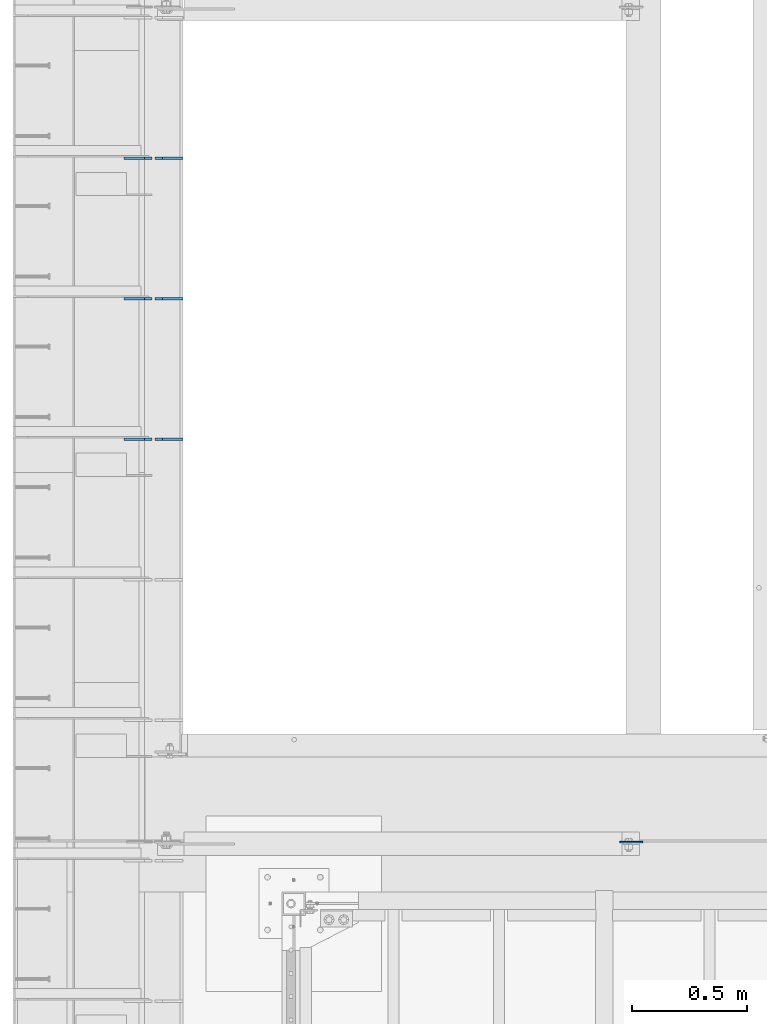
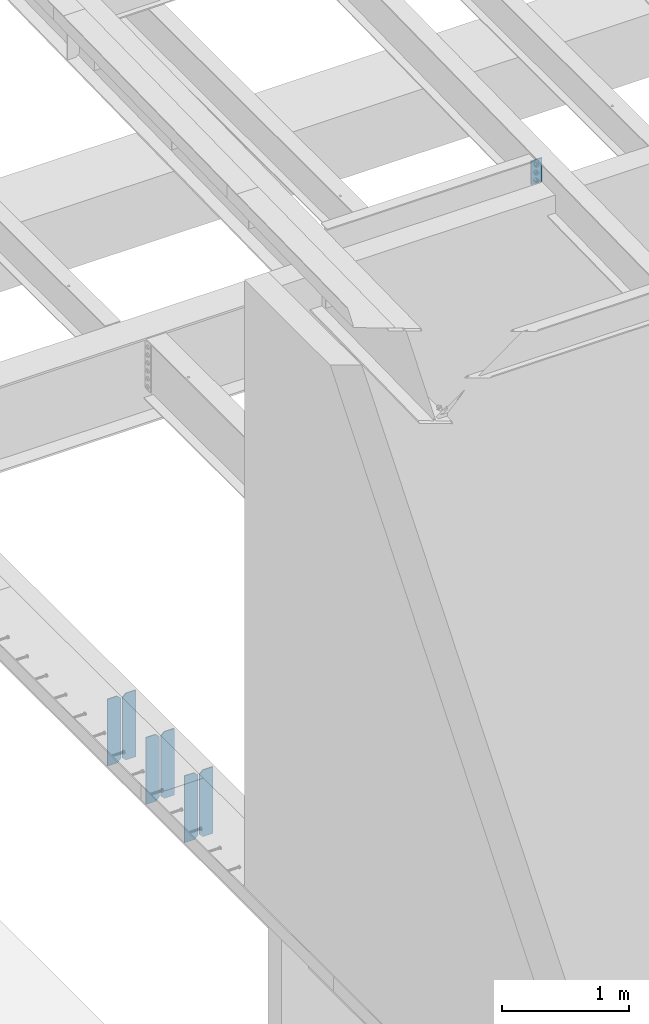
# One storey, part 1516 of 1763: 7 plates, 2 elements without a shape of their own.
"""IFC2X3 building model written with IfcOpenShell, lengths in millimetres."""

from ifc_helpers import new_model, si_unit, frame, origin_with_axes, place, context, subcontext, project, spatial, faceted_brep, material, type_object, element, aggregate, save


model = new_model("IFC2X3")

# Units and contexts
model_context = context("Model", 3, precision=1e-05, world=origin_with_axes())
body_context = subcontext(model_context, "Body", "Model", "MODEL_VIEW")
ifc_project = project(units=[si_unit("LENGTHUNIT", "METRE", prefix="MILLI"), si_unit("AREAUNIT", "SQUARE_METRE"), si_unit("VOLUMEUNIT", "CUBIC_METRE"), si_unit("MASSUNIT", "GRAM", prefix="KILO"), si_unit("TIMEUNIT", "SECOND"), si_unit("PLANEANGLEUNIT", "RADIAN"), si_unit("SOLIDANGLEUNIT", "STERADIAN"), si_unit("THERMODYNAMICTEMPERATUREUNIT", "DEGREE_CELSIUS"), si_unit("LUMINOUSINTENSITYUNIT", "LUMEN")], contexts=[model_context])

# Site, building, storey
site_placement = place(None, origin_with_axes())
site = spatial("IfcSite", under=ifc_project, at=site_placement, CompositionType="ELEMENT")
building_placement = place(site_placement, origin_with_axes())
building = spatial("IfcBuilding", under=site, at=building_placement, Name="Undefined", CompositionType="ELEMENT")
storey_placement = place(building_placement, origin_with_axes())
storey = spatial("IfcBuildingStorey", under=building, at=storey_placement, Name="Undefined", CompositionType="ELEMENT", Elevation=0.0)

# Assembly, plates
assembly_1_placement = place(storey_placement, origin_with_axes())
assembly_1 = element("IfcElementAssembly", 1, at=assembly_1_placement, inside=storey, Name="BEAM", AssemblyPlace="NOTDEFINED", PredefinedType="RIGID_FRAME")
ifc_material = material(Name="STEEL/A36")
plate_type_1 = type_object("IfcPlateType", PredefinedType="NOTDEFINED")
plate_1_placement = place(assembly_1_placement, frame((-87246.8497736984, 39314.4375, 4525.9625), z_axis=(0.0, 0.0, 1.0), x_axis=(-1.0, 0.0, 0.0)))
plate_1 = element("IfcPlate", 2, at=plate_1_placement, type_object=plate_type_1, material=ifc_material, Name="PLATE", context=body_context, shape_type="Brep", body=[
    faceted_brep([(0.0, -4.76249999999982, 0.0), (0.0, -4.76250000000073, 644.525024414062), (0.0, 4.76250000000073, 644.525024414062), (0.0, 4.76249999999982, 0.0), (89.6937484741211, -4.76250000000073, 644.525024414062), (89.6937484741211, 4.76250000000073, 644.525024414062), (121.443748474121, -4.76250000000073, 612.775024414062), (121.443748474121, 4.76250000000073, 612.775024414062), (121.443748474121, -4.76250000000073, 31.75), (121.443748474121, 4.76250000000073, 31.75), (89.6937484741211, -4.76249999999709, 0.0), (89.6937484741211, 4.76249999999709, 0.0)], [[[0, 1, 2, 3]], [[1, 4, 5, 2]], [[4, 6, 7, 5]], [[6, 8, 9, 7]], [[8, 10, 11, 9]], [[10, 0, 3, 11]], [[5, 7, 9, 11, 3, 2]], [[10, 8, 6, 4, 1, 0]]]),
])
plate_2_placement = place(assembly_1_placement, frame((-87382.5810236984, 39314.4375, 4525.9625), z_axis=(0.0, 0.0, 1.0), x_axis=(-1.0, 0.0, 0.0)))
plate_2 = element("IfcPlate", 3, at=plate_2_placement, type_object=plate_type_1, material=ifc_material, Name="PLATE", context=body_context, shape_type="Brep", body=[
    faceted_brep([(0.0, -4.76250000000073, 31.75), (0.0, -4.76250000000073, 612.775024414062), (0.0, 4.76250000000073, 612.775024414062), (0.0, 4.76250000000073, 31.75), (31.75, -4.76250000000073, 644.525024414062), (31.75, 4.76250000000073, 644.525024414062), (121.443748474121, -4.76250000000073, 644.525024414062), (121.443748474121, 4.76250000000073, 644.525024414062), (121.443748474121, -4.76250000000073, 0.0), (121.443748474121, 4.76250000000073, 0.0), (31.75, -4.76250000000073, 0.0), (31.75, 4.76250000000073, 0.0)], [[[0, 1, 2, 3]], [[1, 4, 5, 2]], [[4, 6, 7, 5]], [[6, 8, 9, 7]], [[8, 10, 11, 9]], [[10, 0, 3, 11]], [[5, 7, 9, 11, 3, 2]], [[10, 8, 6, 4, 1, 0]]]),
])
plate_3_placement = place(assembly_1_placement, frame((-87246.8497736984, 39924.0375, 4525.9625), z_axis=(0.0, 0.0, 1.0), x_axis=(-1.0, 0.0, 0.0)))
plate_3 = element("IfcPlate", 4, at=plate_3_placement, type_object=plate_type_1, material=ifc_material, Name="PLATE", context=body_context, shape_type="Brep", body=[
    faceted_brep([(0.0, -4.76249999999982, 0.0), (0.0, -4.76250000000073, 644.525024414062), (0.0, 4.76250000000073, 644.525024414062), (0.0, 4.76249999999982, 0.0), (89.6937484741211, -4.76250000000073, 644.525024414062), (89.6937484741211, 4.76250000000073, 644.525024414062), (121.443748474121, -4.76250000000073, 612.775024414062), (121.443748474121, 4.76250000000073, 612.775024414062), (121.443748474121, -4.76250000000073, 31.75), (121.443748474121, 4.76250000000073, 31.75), (89.6937484741211, -4.76249999999709, 0.0), (89.6937484741211, 4.76249999999709, 0.0)], [[[0, 1, 2, 3]], [[1, 4, 5, 2]], [[4, 6, 7, 5]], [[6, 8, 9, 7]], [[8, 10, 11, 9]], [[10, 0, 3, 11]], [[5, 7, 9, 11, 3, 2]], [[10, 8, 6, 4, 1, 0]]]),
])
plate_4_placement = place(assembly_1_placement, frame((-87382.5810236984, 39924.0375, 4525.9625), z_axis=(0.0, 0.0, 1.0), x_axis=(-1.0, 0.0, 0.0)))
plate_4 = element("IfcPlate", 5, at=plate_4_placement, type_object=plate_type_1, material=ifc_material, Name="PLATE", context=body_context, shape_type="Brep", body=[
    faceted_brep([(0.0, -4.76250000000073, 31.75), (0.0, -4.76250000000073, 612.775024414062), (0.0, 4.76250000000073, 612.775024414062), (0.0, 4.76250000000073, 31.75), (31.75, -4.76250000000073, 644.525024414062), (31.75, 4.76250000000073, 644.525024414062), (121.443748474121, -4.76250000000073, 644.525024414062), (121.443748474121, 4.76250000000073, 644.525024414062), (121.443748474121, -4.76250000000073, 0.0), (121.443748474121, 4.76250000000073, 0.0), (31.75, -4.76250000000073, 0.0), (31.75, 4.76250000000073, 0.0)], [[[0, 1, 2, 3]], [[1, 4, 5, 2]], [[4, 6, 7, 5]], [[6, 8, 9, 7]], [[8, 10, 11, 9]], [[10, 0, 3, 11]], [[5, 7, 9, 11, 3, 2]], [[10, 8, 6, 4, 1, 0]]]),
])
plate_5_placement = place(assembly_1_placement, frame((-87246.8497736984, 40533.6375, 4525.9625), z_axis=(0.0, 0.0, 1.0), x_axis=(-1.0, 0.0, 0.0)))
plate_5 = element("IfcPlate", 6, at=plate_5_placement, type_object=plate_type_1, material=ifc_material, Name="PLATE", context=body_context, shape_type="Brep", body=[
    faceted_brep([(0.0, -4.76249999999982, 0.0), (0.0, -4.76250000000073, 644.525024414062), (0.0, 4.76250000000073, 644.525024414062), (0.0, 4.76249999999982, 0.0), (89.6937484741211, -4.76250000000073, 644.525024414062), (89.6937484741211, 4.76250000000073, 644.525024414062), (121.443748474121, -4.76250000000073, 612.775024414062), (121.443748474121, 4.76250000000073, 612.775024414062), (121.443748474121, -4.76250000000073, 31.75), (121.443748474121, 4.76250000000073, 31.75), (89.6937484741211, -4.76249999999709, 0.0), (89.6937484741211, 4.76249999999709, 0.0)], [[[0, 1, 2, 3]], [[1, 4, 5, 2]], [[4, 6, 7, 5]], [[6, 8, 9, 7]], [[8, 10, 11, 9]], [[10, 0, 3, 11]], [[5, 7, 9, 11, 3, 2]], [[10, 8, 6, 4, 1, 0]]]),
])
plate_6_placement = place(assembly_1_placement, frame((-87382.5810236984, 40533.6375, 4525.9625), z_axis=(0.0, 0.0, 1.0), x_axis=(-1.0, 0.0, 0.0)))
plate_6 = element("IfcPlate", 7, at=plate_6_placement, type_object=plate_type_1, material=ifc_material, Name="PLATE", context=body_context, shape_type="Brep", body=[
    faceted_brep([(0.0, -4.76250000000073, 31.75), (0.0, -4.76250000000073, 612.775024414062), (0.0, 4.76250000000073, 612.775024414062), (0.0, 4.76250000000073, 31.75), (31.75, -4.76250000000073, 644.525024414062), (31.75, 4.76250000000073, 644.525024414062), (121.443748474121, -4.76250000000073, 644.525024414062), (121.443748474121, 4.76250000000073, 644.525024414062), (121.443748474121, -4.76250000000073, 0.0), (121.443748474121, 4.76250000000073, 0.0), (31.75, -4.76250000000073, 0.0), (31.75, 4.76250000000073, 0.0)], [[[0, 1, 2, 3]], [[1, 4, 5, 2]], [[4, 6, 7, 5]], [[6, 8, 9, 7]], [[8, 10, 11, 9]], [[10, 0, 3, 11]], [[5, 7, 9, 11, 3, 2]], [[10, 8, 6, 4, 1, 0]]]),
])
aggregate(assembly_1, [plate_1, plate_2, plate_3, plate_4, plate_5, plate_6])

# Assembly, plate
assembly_2_placement = place(storey_placement, origin_with_axes())
assembly_2 = element("IfcElementAssembly", 8, at=assembly_2_placement, inside=storey, Name="BEAM", AssemblyPlace="NOTDEFINED", PredefinedType="RIGID_FRAME")
plate_type_2 = type_object("IfcPlateType", PredefinedType="NOTDEFINED")
plate_7_placement = place(assembly_2_placement, frame((-85253.0631665555, 37566.5999999887, 11408.1472385615), z_axis=(-1.0, 0.0, 0.0), x_axis=(0.0, 0.0, -1.0)))
plate_7 = element("IfcPlate", 9, at=plate_7_placement, type_object=plate_type_2, material=ifc_material, Name="PLATE", context=body_context, shape_type="Brep", body=[
    faceted_brep([(1.81898940354586e-12, -3.17500000000291, 0.0), (-2.52839527092874e-10, -3.17500000000001, 98.4250000002357), (4.17785486206412e-08, 3.17500000000001, 98.425000000243), (-1.81898940354586e-12, 3.17499999997381, 0.0), (228.600006103516, -3.17499999999927, 98.4250030517578), (228.600006103516, 3.17499999999927, 98.4250030517578), (228.600006103516, -3.17500000001019, -7.27595761418343e-12), (228.600006103516, 3.17499999999563, -7.27595761418343e-12)], [[[0, 1, 2, 3]], [[1, 4, 5, 2]], [[4, 6, 7, 5]], [[6, 0, 3, 7]], [[5, 7, 3, 2]], [[6, 4, 1, 0]]]),
])
aggregate(assembly_2, [plate_7])

save(model, "model.ifc")
